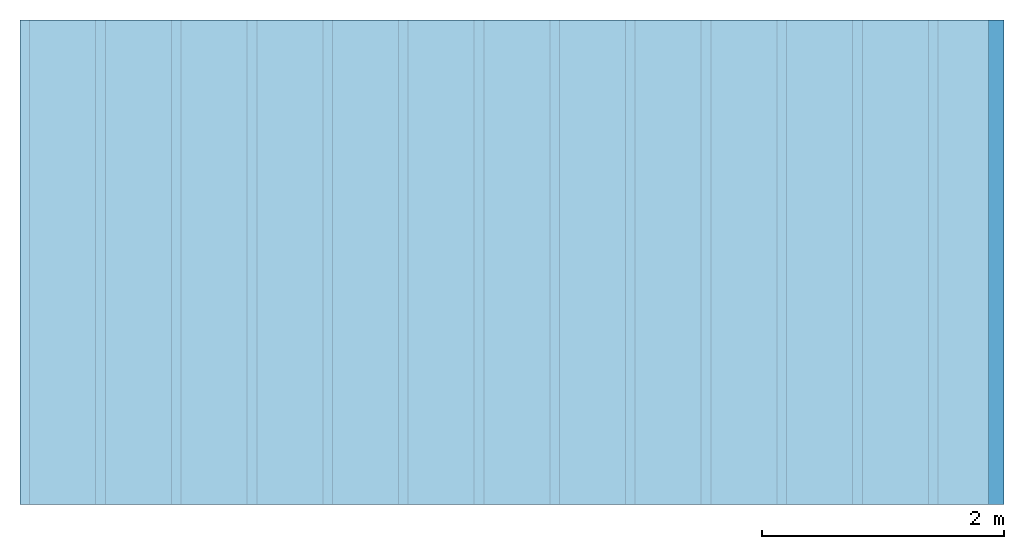
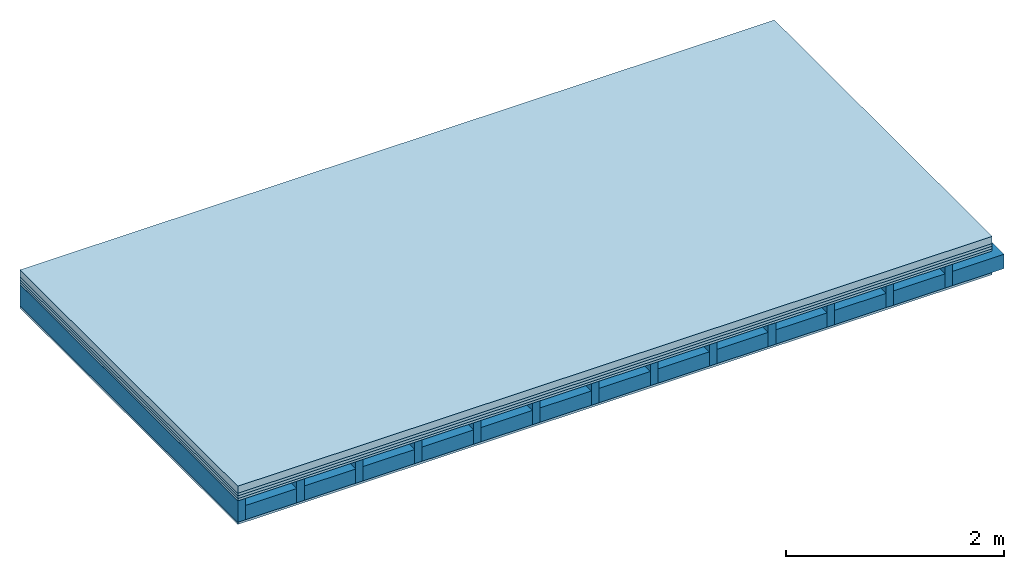
# One storey: 5 plates, 2 members, 1 element without a shape of its own.
"""IFC4 building model written with IfcOpenShell, lengths in metres."""

from ifc_helpers import new_model, si_unit, derived_unit, direction, frame, frame_2d, origin, origin_with_axes, place, context, project, spatial, rectangle, extrude, material, layer, layer_set, type_object, element, aggregate, save


model = new_model("IFC4")

# Units and contexts
plan_context = context("Plan", 3, precision=1e-05, world=origin(), true_north=direction((0.0, 1.0)))
model_context = context("Model", 3, precision=1e-05, world=origin(), true_north=direction((0.0, 1.0)))
ifc_project = project(units=[si_unit("LENGTHUNIT", "METRE"), derived_unit("SOUNDPRESSUREUNIT", [(si_unit("PRESSUREUNIT", "PASCAL", prefix="MICRO"), 0)]), si_unit("ENERGYUNIT", "JOULE", prefix="MEGA"), si_unit("MASSUNIT", "GRAM", prefix="KILO"), derived_unit("THERMALTRANSMITTANCEUNIT", [(si_unit("POWERUNIT", "WATT"), 1), (si_unit("AREAUNIT", "SQUARE_METRE"), -1), (si_unit("THERMODYNAMICTEMPERATUREUNIT", "KELVIN"), -1)]), derived_unit("AREADENSITYUNIT", [(si_unit("MASSUNIT", "GRAM", prefix="KILO"), 1), (si_unit("AREAUNIT", "SQUARE_METRE"), -1)]), derived_unit("USERDEFINED", [(si_unit("ENERGYUNIT", "JOULE", prefix="MEGA"), 1), (si_unit("AREAUNIT", "SQUARE_METRE"), -1)])], contexts=[plan_context, model_context])

# Site, building, storey
site = spatial("IfcSite", under=ifc_project)
building_placement = place(None, origin())
building = spatial("IfcBuilding", under=site, at=building_placement)
storey_placement = place(building_placement, origin())
storey = spatial("IfcBuildingStorey", under=building, at=storey_placement)

# Slab, members, plates
ifc_material_1 = material(Name="Cement screed", Category="04.006")
ifc_layer_1 = layer(ifc_material_1, 0.08, Name="On-material")
ifc_material_2 = material()
ifc_layer_2 = layer(ifc_material_2, 0.03, Name="Impact sound insulation")
ifc_material_3 = material()
ifc_layer_3 = layer(ifc_material_3, 0.03, Name="Additional insulation")
ifc_material_4 = material(Category="07.001")
ifc_layer_4 = layer(ifc_material_4, 0.025, Name="Sub-floor")
ifc_material_5 = material(Name="Rigid, of the art")
ifc_layer_5 = layer(ifc_material_5, 0.0, Name="Bond")
ifc_layer_6 = layer(None, 0.24, Name="Supporting structure")
ifc_layer_7 = layer(ifc_material_5, 0.0, Name="Bond")
ifc_layer_8 = layer(ifc_material_4, 0.025, Name="Lower layer 1")
ifc_layer_set = layer_set([ifc_layer_1, ifc_layer_2, ifc_layer_3, ifc_layer_4, ifc_layer_5, ifc_layer_6, ifc_layer_7, ifc_layer_8])
slab_type = type_object("IfcSlabType", Name="A0449", PredefinedType="NOTDEFINED", material=ifc_layer_set)
slab_placement = place(None, frame((0.0, 0.0, 0.0), z_axis=(0.0, 0.0, -1.0), x_axis=(1.0, 0.0, 0.0)))
slab = element("IfcSlab", 1, at=slab_placement, inside=storey, type_object=slab_type, material=ifc_layer_set, Name="Slab #1")
ifc_material_6 = material()
member_1_placement = place(slab_placement, origin())
member_1 = element("IfcMember", 2, at=member_1_placement, material=ifc_material_6, Name="Supporting structure", context=plan_context, shape_type="SweptSolid", body=[
    extrude(rectangle(XDim=0.08, YDim=0.24, at=frame_2d((0.04, 0.12), x_axis=(1.0, 0.0))), frame((0.0, 4.0, 0.165), z_axis=(0.0, -1.0, 0.0), x_axis=(1.0, 0.0, 0.0)), (0.0, 0.0, 1.0), 4.0),
    extrude(rectangle(XDim=0.08, YDim=0.24, at=frame_2d((0.04, 0.12), x_axis=(1.0, 0.0))), frame((0.625, 4.0, 0.165), z_axis=(0.0, -1.0, 0.0), x_axis=(1.0, 0.0, 0.0)), (0.0, 0.0, 1.0), 4.0),
    extrude(rectangle(XDim=0.08, YDim=0.24, at=frame_2d((0.04, 0.12), x_axis=(1.0, 0.0))), frame((1.25, 4.0, 0.165), z_axis=(0.0, -1.0, 0.0), x_axis=(1.0, 0.0, 0.0)), (0.0, 0.0, 1.0), 4.0),
    extrude(rectangle(XDim=0.08, YDim=0.24, at=frame_2d((0.04, 0.12), x_axis=(1.0, 0.0))), frame((1.875, 4.0, 0.165), z_axis=(0.0, -1.0, 0.0), x_axis=(1.0, 0.0, 0.0)), (0.0, 0.0, 1.0), 4.0),
    extrude(rectangle(XDim=0.08, YDim=0.24, at=frame_2d((0.04, 0.12), x_axis=(1.0, 0.0))), frame((2.5, 4.0, 0.165), z_axis=(0.0, -1.0, 0.0), x_axis=(1.0, 0.0, 0.0)), (0.0, 0.0, 1.0), 4.0),
    extrude(rectangle(XDim=0.08, YDim=0.24, at=frame_2d((0.04, 0.12), x_axis=(1.0, 0.0))), frame((3.125, 4.0, 0.165), z_axis=(0.0, -1.0, 0.0), x_axis=(1.0, 0.0, 0.0)), (0.0, 0.0, 1.0), 4.0),
    extrude(rectangle(XDim=0.08, YDim=0.24, at=frame_2d((0.04, 0.12), x_axis=(1.0, 0.0))), frame((3.75, 4.0, 0.165), z_axis=(0.0, -1.0, 0.0), x_axis=(1.0, 0.0, 0.0)), (0.0, 0.0, 1.0), 4.0),
    extrude(rectangle(XDim=0.08, YDim=0.24, at=frame_2d((0.04, 0.12), x_axis=(1.0, 0.0))), frame((4.375, 4.0, 0.165), z_axis=(0.0, -1.0, 0.0), x_axis=(1.0, 0.0, 0.0)), (0.0, 0.0, 1.0), 4.0),
    extrude(rectangle(XDim=0.08, YDim=0.24, at=frame_2d((0.04, 0.12), x_axis=(1.0, 0.0))), frame((5.0, 4.0, 0.165), z_axis=(0.0, -1.0, 0.0), x_axis=(1.0, 0.0, 0.0)), (0.0, 0.0, 1.0), 4.0),
    extrude(rectangle(XDim=0.08, YDim=0.24, at=frame_2d((0.04, 0.12), x_axis=(1.0, 0.0))), frame((5.625, 4.0, 0.165), z_axis=(0.0, -1.0, 0.0), x_axis=(1.0, 0.0, 0.0)), (0.0, 0.0, 1.0), 4.0),
    extrude(rectangle(XDim=0.08, YDim=0.24, at=frame_2d((0.04, 0.12), x_axis=(1.0, 0.0))), frame((6.25, 4.0, 0.165), z_axis=(0.0, -1.0, 0.0), x_axis=(1.0, 0.0, 0.0)), (0.0, 0.0, 1.0), 4.0),
    extrude(rectangle(XDim=0.08, YDim=0.24, at=frame_2d((0.04, 0.12), x_axis=(1.0, 0.0))), frame((6.875, 4.0, 0.165), z_axis=(0.0, -1.0, 0.0), x_axis=(1.0, 0.0, 0.0)), (0.0, 0.0, 1.0), 4.0),
    extrude(rectangle(XDim=0.08, YDim=0.24, at=frame_2d((0.04, 0.12), x_axis=(1.0, 0.0))), frame((7.5, 4.0, 0.165), z_axis=(0.0, -1.0, 0.0), x_axis=(1.0, 0.0, 0.0)), (0.0, 0.0, 1.0), 4.0),
])
ifc_material_7 = material()
member_2_placement = place(slab_placement, origin())
member_2 = element("IfcMember", 3, at=member_2_placement, material=ifc_material_7, Name="in supporting structure", context=plan_context, shape_type="SweptSolid", body=[
    extrude(rectangle(XDim=0.545, YDim=0.16, at=frame_2d((0.2725, 0.08), x_axis=(1.0, 0.0))), frame((0.08, 4.0, 0.245), z_axis=(0.0, -1.0, 0.0), x_axis=(1.0, 0.0, 0.0)), (0.0, 0.0, 1.0), 4.0),
    extrude(rectangle(XDim=0.545, YDim=0.16, at=frame_2d((0.2725, 0.08), x_axis=(1.0, 0.0))), frame((0.705, 4.0, 0.245), z_axis=(0.0, -1.0, 0.0), x_axis=(1.0, 0.0, 0.0)), (0.0, 0.0, 1.0), 4.0),
    extrude(rectangle(XDim=0.545, YDim=0.16, at=frame_2d((0.2725, 0.08), x_axis=(1.0, 0.0))), frame((1.33, 4.0, 0.245), z_axis=(0.0, -1.0, 0.0), x_axis=(1.0, 0.0, 0.0)), (0.0, 0.0, 1.0), 4.0),
    extrude(rectangle(XDim=0.545, YDim=0.16, at=frame_2d((0.2725, 0.08), x_axis=(1.0, 0.0))), frame((1.955, 4.0, 0.245), z_axis=(0.0, -1.0, 0.0), x_axis=(1.0, 0.0, 0.0)), (0.0, 0.0, 1.0), 4.0),
    extrude(rectangle(XDim=0.545, YDim=0.16, at=frame_2d((0.2725, 0.08), x_axis=(1.0, 0.0))), frame((2.58, 4.0, 0.245), z_axis=(0.0, -1.0, 0.0), x_axis=(1.0, 0.0, 0.0)), (0.0, 0.0, 1.0), 4.0),
    extrude(rectangle(XDim=0.545, YDim=0.16, at=frame_2d((0.2725, 0.08), x_axis=(1.0, 0.0))), frame((3.205, 4.0, 0.245), z_axis=(0.0, -1.0, 0.0), x_axis=(1.0, 0.0, 0.0)), (0.0, 0.0, 1.0), 4.0),
    extrude(rectangle(XDim=0.545, YDim=0.16, at=frame_2d((0.2725, 0.08), x_axis=(1.0, 0.0))), frame((3.83, 4.0, 0.245), z_axis=(0.0, -1.0, 0.0), x_axis=(1.0, 0.0, 0.0)), (0.0, 0.0, 1.0), 4.0),
    extrude(rectangle(XDim=0.545, YDim=0.16, at=frame_2d((0.2725, 0.08), x_axis=(1.0, 0.0))), frame((4.455, 4.0, 0.245), z_axis=(0.0, -1.0, 0.0), x_axis=(1.0, 0.0, 0.0)), (0.0, 0.0, 1.0), 4.0),
    extrude(rectangle(XDim=0.545, YDim=0.16, at=frame_2d((0.2725, 0.08), x_axis=(1.0, 0.0))), frame((5.08, 4.0, 0.245), z_axis=(0.0, -1.0, 0.0), x_axis=(1.0, 0.0, 0.0)), (0.0, 0.0, 1.0), 4.0),
    extrude(rectangle(XDim=0.545, YDim=0.16, at=frame_2d((0.2725, 0.08), x_axis=(1.0, 0.0))), frame((5.705, 4.0, 0.245), z_axis=(0.0, -1.0, 0.0), x_axis=(1.0, 0.0, 0.0)), (0.0, 0.0, 1.0), 4.0),
    extrude(rectangle(XDim=0.545, YDim=0.16, at=frame_2d((0.2725, 0.08), x_axis=(1.0, 0.0))), frame((6.33, 4.0, 0.245), z_axis=(0.0, -1.0, 0.0), x_axis=(1.0, 0.0, 0.0)), (0.0, 0.0, 1.0), 4.0),
    extrude(rectangle(XDim=0.545, YDim=0.16, at=frame_2d((0.2725, 0.08), x_axis=(1.0, 0.0))), frame((6.955, 4.0, 0.245), z_axis=(0.0, -1.0, 0.0), x_axis=(1.0, 0.0, 0.0)), (0.0, 0.0, 1.0), 4.0),
    extrude(rectangle(XDim=0.545, YDim=0.16, at=frame_2d((0.2725, 0.08), x_axis=(1.0, 0.0))), frame((7.58, 4.0, 0.245), z_axis=(0.0, -1.0, 0.0), x_axis=(1.0, 0.0, 0.0)), (0.0, 0.0, 1.0), 4.0),
])
plate_1_placement = place(slab_placement, origin())
plate_1 = element("IfcPlate", 4, at=plate_1_placement, material=ifc_material_1, Name="On-material", context=plan_context, shape_type="SweptSolid", body=[
    extrude(rectangle(XDim=8.0, YDim=4.0, at=frame_2d((4.0, 2.0), x_axis=(1.0, 0.0))), origin_with_axes(), (0.0, 0.0, 1.0), 0.08),
])
plate_2_placement = place(slab_placement, origin())
plate_2 = element("IfcPlate", 5, at=plate_2_placement, material=ifc_material_2, Name="Impact sound insulation", context=plan_context, shape_type="SweptSolid", body=[
    extrude(rectangle(XDim=8.0, YDim=4.0, at=frame_2d((4.0, 2.0), x_axis=(1.0, 0.0))), frame((0.0, 0.0, 0.08), z_axis=(0.0, 0.0, 1.0), x_axis=(1.0, 0.0, 0.0)), (0.0, 0.0, 1.0), 0.03),
])
plate_3_placement = place(slab_placement, origin())
plate_3 = element("IfcPlate", 6, at=plate_3_placement, material=ifc_material_3, Name="Additional insulation", context=plan_context, shape_type="SweptSolid", body=[
    extrude(rectangle(XDim=8.0, YDim=4.0, at=frame_2d((4.0, 2.0), x_axis=(1.0, 0.0))), frame((0.0, 0.0, 0.11), z_axis=(0.0, 0.0, 1.0), x_axis=(1.0, 0.0, 0.0)), (0.0, 0.0, 1.0), 0.03),
])
plate_4_placement = place(slab_placement, origin())
plate_4 = element("IfcPlate", 7, at=plate_4_placement, material=ifc_material_4, Name="Sub-floor", context=plan_context, shape_type="SweptSolid", body=[
    extrude(rectangle(XDim=8.0, YDim=4.0, at=frame_2d((4.0, 2.0), x_axis=(1.0, 0.0))), frame((0.0, 0.0, 0.14), z_axis=(0.0, 0.0, 1.0), x_axis=(1.0, 0.0, 0.0)), (0.0, 0.0, 1.0), 0.025),
])
plate_5_placement = place(slab_placement, origin())
plate_5 = element("IfcPlate", 8, at=plate_5_placement, material=ifc_material_4, Name="Lower layer 1", context=plan_context, shape_type="SweptSolid", body=[
    extrude(rectangle(XDim=8.0, YDim=4.0, at=frame_2d((4.0, 2.0), x_axis=(1.0, 0.0))), frame((0.0, 0.0, 0.405), z_axis=(0.0, 0.0, 1.0), x_axis=(1.0, 0.0, 0.0)), (0.0, 0.0, 1.0), 0.025),
])
aggregate(slab, [plate_1, plate_2, plate_3, plate_4, member_1, member_2, plate_5])

save(model, "model.ifc")
